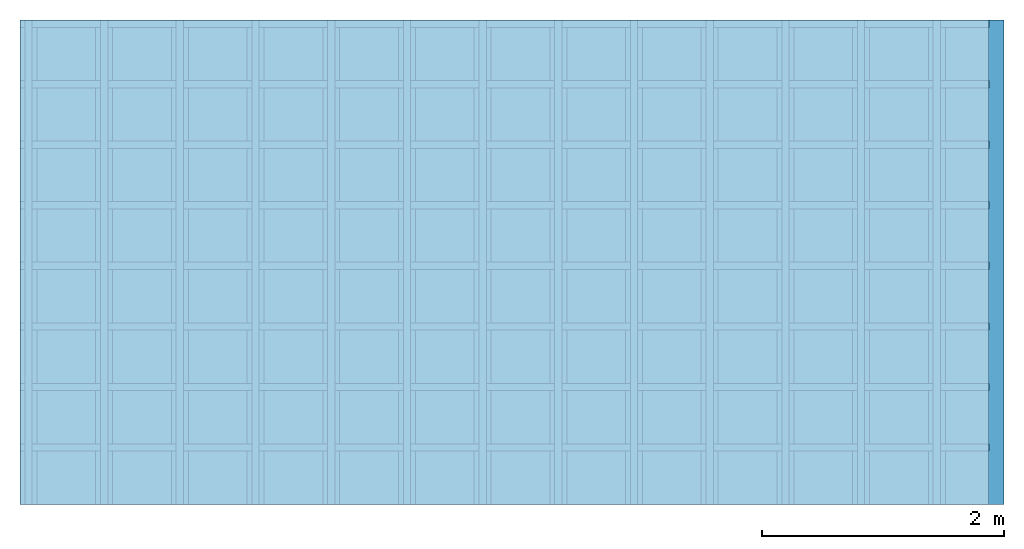
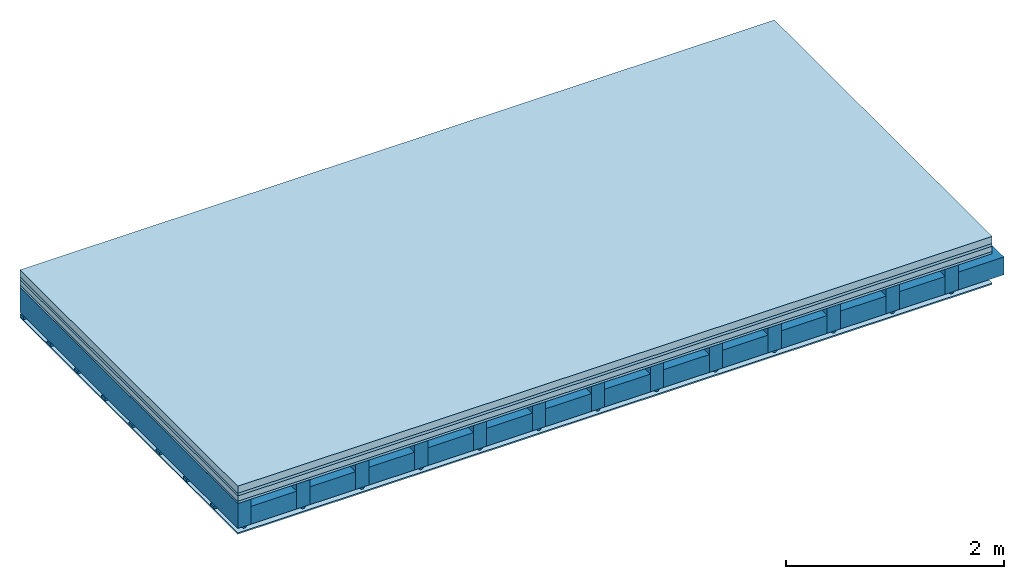
# One storey: 5 plates, 4 members, 1 element without a shape of its own.
"""IFC4 building model written with IfcOpenShell, lengths in metres."""

from ifc_helpers import new_model, si_unit, derived_unit, direction, frame, frame_2d, origin, origin_with_axes, place, context, project, spatial, polyline, rectangle, outline, extrude, material, layer, layer_set, type_object, element, aggregate, save


model = new_model("IFC4")

# Units and contexts
plan_context = context("Plan", 3, precision=1e-05, world=origin(), true_north=direction((0.0, 1.0)))
model_context = context("Model", 3, precision=1e-05, world=origin(), true_north=direction((0.0, 1.0)))
ifc_project = project(units=[si_unit("LENGTHUNIT", "METRE"), derived_unit("SOUNDPRESSUREUNIT", [(si_unit("PRESSUREUNIT", "PASCAL", prefix="MICRO"), 0)]), si_unit("ENERGYUNIT", "JOULE", prefix="MEGA"), si_unit("MASSUNIT", "GRAM", prefix="KILO"), derived_unit("THERMALTRANSMITTANCEUNIT", [(si_unit("POWERUNIT", "WATT"), 1), (si_unit("AREAUNIT", "SQUARE_METRE"), -1), (si_unit("THERMODYNAMICTEMPERATUREUNIT", "KELVIN"), -1)]), derived_unit("AREADENSITYUNIT", [(si_unit("MASSUNIT", "GRAM", prefix="KILO"), 1), (si_unit("AREAUNIT", "SQUARE_METRE"), -1)]), derived_unit("USERDEFINED", [(si_unit("ENERGYUNIT", "JOULE", prefix="MEGA"), 1), (si_unit("AREAUNIT", "SQUARE_METRE"), -1)])], contexts=[plan_context, model_context])

# Site, building, storey
site = spatial("IfcSite", under=ifc_project)
building_placement = place(None, origin())
building = spatial("IfcBuilding", under=site, at=building_placement)
storey_placement = place(building_placement, origin())
storey = spatial("IfcBuildingStorey", under=building, at=storey_placement)

# Slab, members, plates
ifc_material_1 = material(Name="Cement screed", Category="04.006")
ifc_layer_1 = layer(ifc_material_1, 0.08, Name="On-material")
ifc_material_2 = material()
ifc_layer_2 = layer(ifc_material_2, 0.03, Name="Impact sound insulation")
ifc_material_3 = material(Category="03.011")
ifc_layer_3 = layer(ifc_material_3, 0.06, Name="on Supporting structure")
ifc_material_4 = material(Category="07.001")
ifc_layer_4 = layer(ifc_material_4, 0.025, Name="Sub-floor")
ifc_material_5 = material(Name="of the art")
ifc_layer_5 = layer(ifc_material_5, 0.0, Name="Bond")
ifc_layer_6 = layer(None, 0.28, Name="Supporting structure")
ifc_material_6 = material(Name="no composite action")
ifc_layer_7 = layer(ifc_material_6, 0.0, Name="Bond")
ifc_layer_8 = layer(None, 0.02, Name="Coupling")
ifc_layer_9 = layer(None, 0.03, Name="Battens / profiles")
ifc_material_7 = material(Category="03.007")
ifc_layer_10 = layer(ifc_material_7, 0.015, Name="Ceiling covering 1st layer")
ifc_material_8 = material(Name="Glued joints")
ifc_layer_11 = layer(ifc_material_8, 0.0, Name="Surface / treatment")
ifc_layer_set = layer_set([ifc_layer_1, ifc_layer_2, ifc_layer_3, ifc_layer_4, ifc_layer_5, ifc_layer_6, ifc_layer_7, ifc_layer_8, ifc_layer_9, ifc_layer_10, ifc_layer_11])
slab_type = type_object("IfcSlabType", Name="A0266", PredefinedType="NOTDEFINED", material=ifc_layer_set)
slab_placement = place(None, frame((0.0, 0.0, 0.0), z_axis=(0.0, 0.0, -1.0), x_axis=(1.0, 0.0, 0.0)))
slab = element("IfcSlab", 1, at=slab_placement, inside=storey, type_object=slab_type, material=ifc_layer_set, Name="Slab #1")
ifc_material_9 = material()
member_1_placement = place(slab_placement, origin())
member_1 = element("IfcMember", 2, at=member_1_placement, material=ifc_material_9, Name="Supporting structure", context=plan_context, shape_type="SweptSolid", body=[
    extrude(rectangle(XDim=0.14, YDim=0.28, at=frame_2d((0.07, 0.14), x_axis=(1.0, 0.0))), frame((0.0, 4.0, 0.195), z_axis=(0.0, -1.0, 0.0), x_axis=(1.0, 0.0, 0.0)), (0.0, 0.0, 1.0), 4.0),
    extrude(rectangle(XDim=0.14, YDim=0.28, at=frame_2d((0.07, 0.14), x_axis=(1.0, 0.0))), frame((0.625, 4.0, 0.195), z_axis=(0.0, -1.0, 0.0), x_axis=(1.0, 0.0, 0.0)), (0.0, 0.0, 1.0), 4.0),
    extrude(rectangle(XDim=0.14, YDim=0.28, at=frame_2d((0.07, 0.14), x_axis=(1.0, 0.0))), frame((1.25, 4.0, 0.195), z_axis=(0.0, -1.0, 0.0), x_axis=(1.0, 0.0, 0.0)), (0.0, 0.0, 1.0), 4.0),
    extrude(rectangle(XDim=0.14, YDim=0.28, at=frame_2d((0.07, 0.14), x_axis=(1.0, 0.0))), frame((1.875, 4.0, 0.195), z_axis=(0.0, -1.0, 0.0), x_axis=(1.0, 0.0, 0.0)), (0.0, 0.0, 1.0), 4.0),
    extrude(rectangle(XDim=0.14, YDim=0.28, at=frame_2d((0.07, 0.14), x_axis=(1.0, 0.0))), frame((2.5, 4.0, 0.195), z_axis=(0.0, -1.0, 0.0), x_axis=(1.0, 0.0, 0.0)), (0.0, 0.0, 1.0), 4.0),
    extrude(rectangle(XDim=0.14, YDim=0.28, at=frame_2d((0.07, 0.14), x_axis=(1.0, 0.0))), frame((3.125, 4.0, 0.195), z_axis=(0.0, -1.0, 0.0), x_axis=(1.0, 0.0, 0.0)), (0.0, 0.0, 1.0), 4.0),
    extrude(rectangle(XDim=0.14, YDim=0.28, at=frame_2d((0.07, 0.14), x_axis=(1.0, 0.0))), frame((3.75, 4.0, 0.195), z_axis=(0.0, -1.0, 0.0), x_axis=(1.0, 0.0, 0.0)), (0.0, 0.0, 1.0), 4.0),
    extrude(rectangle(XDim=0.14, YDim=0.28, at=frame_2d((0.07, 0.14), x_axis=(1.0, 0.0))), frame((4.375, 4.0, 0.195), z_axis=(0.0, -1.0, 0.0), x_axis=(1.0, 0.0, 0.0)), (0.0, 0.0, 1.0), 4.0),
    extrude(rectangle(XDim=0.14, YDim=0.28, at=frame_2d((0.07, 0.14), x_axis=(1.0, 0.0))), frame((5.0, 4.0, 0.195), z_axis=(0.0, -1.0, 0.0), x_axis=(1.0, 0.0, 0.0)), (0.0, 0.0, 1.0), 4.0),
    extrude(rectangle(XDim=0.14, YDim=0.28, at=frame_2d((0.07, 0.14), x_axis=(1.0, 0.0))), frame((5.625, 4.0, 0.195), z_axis=(0.0, -1.0, 0.0), x_axis=(1.0, 0.0, 0.0)), (0.0, 0.0, 1.0), 4.0),
    extrude(rectangle(XDim=0.14, YDim=0.28, at=frame_2d((0.07, 0.14), x_axis=(1.0, 0.0))), frame((6.25, 4.0, 0.195), z_axis=(0.0, -1.0, 0.0), x_axis=(1.0, 0.0, 0.0)), (0.0, 0.0, 1.0), 4.0),
    extrude(rectangle(XDim=0.14, YDim=0.28, at=frame_2d((0.07, 0.14), x_axis=(1.0, 0.0))), frame((6.875, 4.0, 0.195), z_axis=(0.0, -1.0, 0.0), x_axis=(1.0, 0.0, 0.0)), (0.0, 0.0, 1.0), 4.0),
    extrude(rectangle(XDim=0.14, YDim=0.28, at=frame_2d((0.07, 0.14), x_axis=(1.0, 0.0))), frame((7.5, 4.0, 0.195), z_axis=(0.0, -1.0, 0.0), x_axis=(1.0, 0.0, 0.0)), (0.0, 0.0, 1.0), 4.0),
])
ifc_material_10 = material()
member_2_placement = place(slab_placement, origin())
member_2 = element("IfcMember", 3, at=member_2_placement, material=ifc_material_10, Name="Cavity", context=plan_context, shape_type="SweptSolid", body=[
    extrude(rectangle(XDim=0.485, YDim=0.2, at=frame_2d((0.2425, 0.1), x_axis=(1.0, 0.0))), frame((0.14, 4.0, 0.275), z_axis=(0.0, -1.0, 0.0), x_axis=(1.0, 0.0, 0.0)), (0.0, 0.0, 1.0), 4.0),
    extrude(rectangle(XDim=0.485, YDim=0.2, at=frame_2d((0.2425, 0.1), x_axis=(1.0, 0.0))), frame((0.765, 4.0, 0.275), z_axis=(0.0, -1.0, 0.0), x_axis=(1.0, 0.0, 0.0)), (0.0, 0.0, 1.0), 4.0),
    extrude(rectangle(XDim=0.485, YDim=0.2, at=frame_2d((0.2425, 0.1), x_axis=(1.0, 0.0))), frame((1.39, 4.0, 0.275), z_axis=(0.0, -1.0, 0.0), x_axis=(1.0, 0.0, 0.0)), (0.0, 0.0, 1.0), 4.0),
    extrude(rectangle(XDim=0.485, YDim=0.2, at=frame_2d((0.2425, 0.1), x_axis=(1.0, 0.0))), frame((2.015, 4.0, 0.275), z_axis=(0.0, -1.0, 0.0), x_axis=(1.0, 0.0, 0.0)), (0.0, 0.0, 1.0), 4.0),
    extrude(rectangle(XDim=0.485, YDim=0.2, at=frame_2d((0.2425, 0.1), x_axis=(1.0, 0.0))), frame((2.64, 4.0, 0.275), z_axis=(0.0, -1.0, 0.0), x_axis=(1.0, 0.0, 0.0)), (0.0, 0.0, 1.0), 4.0),
    extrude(rectangle(XDim=0.485, YDim=0.2, at=frame_2d((0.2425, 0.1), x_axis=(1.0, 0.0))), frame((3.265, 4.0, 0.275), z_axis=(0.0, -1.0, 0.0), x_axis=(1.0, 0.0, 0.0)), (0.0, 0.0, 1.0), 4.0),
    extrude(rectangle(XDim=0.485, YDim=0.2, at=frame_2d((0.2425, 0.1), x_axis=(1.0, 0.0))), frame((3.89, 4.0, 0.275), z_axis=(0.0, -1.0, 0.0), x_axis=(1.0, 0.0, 0.0)), (0.0, 0.0, 1.0), 4.0),
    extrude(rectangle(XDim=0.485, YDim=0.2, at=frame_2d((0.2425, 0.1), x_axis=(1.0, 0.0))), frame((4.515, 4.0, 0.275), z_axis=(0.0, -1.0, 0.0), x_axis=(1.0, 0.0, 0.0)), (0.0, 0.0, 1.0), 4.0),
    extrude(rectangle(XDim=0.485, YDim=0.2, at=frame_2d((0.2425, 0.1), x_axis=(1.0, 0.0))), frame((5.14, 4.0, 0.275), z_axis=(0.0, -1.0, 0.0), x_axis=(1.0, 0.0, 0.0)), (0.0, 0.0, 1.0), 4.0),
    extrude(rectangle(XDim=0.485, YDim=0.2, at=frame_2d((0.2425, 0.1), x_axis=(1.0, 0.0))), frame((5.765, 4.0, 0.275), z_axis=(0.0, -1.0, 0.0), x_axis=(1.0, 0.0, 0.0)), (0.0, 0.0, 1.0), 4.0),
    extrude(rectangle(XDim=0.485, YDim=0.2, at=frame_2d((0.2425, 0.1), x_axis=(1.0, 0.0))), frame((6.39, 4.0, 0.275), z_axis=(0.0, -1.0, 0.0), x_axis=(1.0, 0.0, 0.0)), (0.0, 0.0, 1.0), 4.0),
    extrude(rectangle(XDim=0.485, YDim=0.2, at=frame_2d((0.2425, 0.1), x_axis=(1.0, 0.0))), frame((7.015, 4.0, 0.275), z_axis=(0.0, -1.0, 0.0), x_axis=(1.0, 0.0, 0.0)), (0.0, 0.0, 1.0), 4.0),
    extrude(rectangle(XDim=0.485, YDim=0.2, at=frame_2d((0.2425, 0.1), x_axis=(1.0, 0.0))), frame((7.64, 4.0, 0.275), z_axis=(0.0, -1.0, 0.0), x_axis=(1.0, 0.0, 0.0)), (0.0, 0.0, 1.0), 4.0),
])
ifc_material_11 = material()
member_3_placement = place(slab_placement, origin())
member_3 = element("IfcMember", 4, at=member_3_placement, material=ifc_material_11, Name="Coupling", context=plan_context, shape_type="SweptSolid", body=[
    extrude(outline(polyline([(0.0, 0.0), (0.06, 0.0), (0.04, 0.02), (0.02, 0.02), (0.0, 0.0)])), frame((0.04, 4.0, 0.475), z_axis=(0.0, -1.0, 0.0), x_axis=(1.0, 0.0, 0.0)), (0.0, 0.0, 1.0), 4.0),
    extrude(outline(polyline([(0.0, 0.0), (0.06, 0.0), (0.04, 0.02), (0.02, 0.02), (0.0, 0.0)])), frame((0.665, 4.0, 0.475), z_axis=(0.0, -1.0, 0.0), x_axis=(1.0, 0.0, 0.0)), (0.0, 0.0, 1.0), 4.0),
    extrude(outline(polyline([(0.0, 0.0), (0.06, 0.0), (0.04, 0.02), (0.02, 0.02), (0.0, 0.0)])), frame((1.29, 4.0, 0.475), z_axis=(0.0, -1.0, 0.0), x_axis=(1.0, 0.0, 0.0)), (0.0, 0.0, 1.0), 4.0),
    extrude(outline(polyline([(0.0, 0.0), (0.06, 0.0), (0.04, 0.02), (0.02, 0.02), (0.0, 0.0)])), frame((1.915, 4.0, 0.475), z_axis=(0.0, -1.0, 0.0), x_axis=(1.0, 0.0, 0.0)), (0.0, 0.0, 1.0), 4.0),
    extrude(outline(polyline([(0.0, 0.0), (0.06, 0.0), (0.04, 0.02), (0.02, 0.02), (0.0, 0.0)])), frame((2.54, 4.0, 0.475), z_axis=(0.0, -1.0, 0.0), x_axis=(1.0, 0.0, 0.0)), (0.0, 0.0, 1.0), 4.0),
    extrude(outline(polyline([(0.0, 0.0), (0.06, 0.0), (0.04, 0.02), (0.02, 0.02), (0.0, 0.0)])), frame((3.165, 4.0, 0.475), z_axis=(0.0, -1.0, 0.0), x_axis=(1.0, 0.0, 0.0)), (0.0, 0.0, 1.0), 4.0),
    extrude(outline(polyline([(0.0, 0.0), (0.06, 0.0), (0.04, 0.02), (0.02, 0.02), (0.0, 0.0)])), frame((3.79, 4.0, 0.475), z_axis=(0.0, -1.0, 0.0), x_axis=(1.0, 0.0, 0.0)), (0.0, 0.0, 1.0), 4.0),
    extrude(outline(polyline([(0.0, 0.0), (0.06, 0.0), (0.04, 0.02), (0.02, 0.02), (0.0, 0.0)])), frame((4.415, 4.0, 0.475), z_axis=(0.0, -1.0, 0.0), x_axis=(1.0, 0.0, 0.0)), (0.0, 0.0, 1.0), 4.0),
    extrude(outline(polyline([(0.0, 0.0), (0.06, 0.0), (0.04, 0.02), (0.02, 0.02), (0.0, 0.0)])), frame((5.04, 4.0, 0.475), z_axis=(0.0, -1.0, 0.0), x_axis=(1.0, 0.0, 0.0)), (0.0, 0.0, 1.0), 4.0),
    extrude(outline(polyline([(0.0, 0.0), (0.06, 0.0), (0.04, 0.02), (0.02, 0.02), (0.0, 0.0)])), frame((5.665, 4.0, 0.475), z_axis=(0.0, -1.0, 0.0), x_axis=(1.0, 0.0, 0.0)), (0.0, 0.0, 1.0), 4.0),
    extrude(outline(polyline([(0.0, 0.0), (0.06, 0.0), (0.04, 0.02), (0.02, 0.02), (0.0, 0.0)])), frame((6.29, 4.0, 0.475), z_axis=(0.0, -1.0, 0.0), x_axis=(1.0, 0.0, 0.0)), (0.0, 0.0, 1.0), 4.0),
    extrude(outline(polyline([(0.0, 0.0), (0.06, 0.0), (0.04, 0.02), (0.02, 0.02), (0.0, 0.0)])), frame((6.915, 4.0, 0.475), z_axis=(0.0, -1.0, 0.0), x_axis=(1.0, 0.0, 0.0)), (0.0, 0.0, 1.0), 4.0),
    extrude(outline(polyline([(0.0, 0.0), (0.06, 0.0), (0.04, 0.02), (0.02, 0.02), (0.0, 0.0)])), frame((7.54, 4.0, 0.475), z_axis=(0.0, -1.0, 0.0), x_axis=(1.0, 0.0, 0.0)), (0.0, 0.0, 1.0), 4.0),
])
ifc_material_12 = material()
member_4_placement = place(slab_placement, origin())
member_4 = element("IfcMember", 5, at=member_4_placement, material=ifc_material_12, Name="Battens / profiles", context=plan_context, shape_type="SweptSolid", body=[
    extrude(rectangle(XDim=0.06, YDim=0.03, at=frame_2d((0.03, 0.015), x_axis=(1.0, 0.0))), frame((0.0, 0.0, 0.495), z_axis=(1.0, 0.0, 0.0), x_axis=(0.0, 1.0, 0.0)), (0.0, 0.0, 1.0), 8.0),
    extrude(rectangle(XDim=0.06, YDim=0.03, at=frame_2d((0.03, 0.015), x_axis=(1.0, 0.0))), frame((0.0, 0.5, 0.495), z_axis=(1.0, 0.0, 0.0), x_axis=(0.0, 1.0, 0.0)), (0.0, 0.0, 1.0), 8.0),
    extrude(rectangle(XDim=0.06, YDim=0.03, at=frame_2d((0.03, 0.015), x_axis=(1.0, 0.0))), frame((0.0, 1.0, 0.495), z_axis=(1.0, 0.0, 0.0), x_axis=(0.0, 1.0, 0.0)), (0.0, 0.0, 1.0), 8.0),
    extrude(rectangle(XDim=0.06, YDim=0.03, at=frame_2d((0.03, 0.015), x_axis=(1.0, 0.0))), frame((0.0, 1.5, 0.495), z_axis=(1.0, 0.0, 0.0), x_axis=(0.0, 1.0, 0.0)), (0.0, 0.0, 1.0), 8.0),
    extrude(rectangle(XDim=0.06, YDim=0.03, at=frame_2d((0.03, 0.015), x_axis=(1.0, 0.0))), frame((0.0, 2.0, 0.495), z_axis=(1.0, 0.0, 0.0), x_axis=(0.0, 1.0, 0.0)), (0.0, 0.0, 1.0), 8.0),
    extrude(rectangle(XDim=0.06, YDim=0.03, at=frame_2d((0.03, 0.015), x_axis=(1.0, 0.0))), frame((0.0, 2.5, 0.495), z_axis=(1.0, 0.0, 0.0), x_axis=(0.0, 1.0, 0.0)), (0.0, 0.0, 1.0), 8.0),
    extrude(rectangle(XDim=0.06, YDim=0.03, at=frame_2d((0.03, 0.015), x_axis=(1.0, 0.0))), frame((0.0, 3.0, 0.495), z_axis=(1.0, 0.0, 0.0), x_axis=(0.0, 1.0, 0.0)), (0.0, 0.0, 1.0), 8.0),
    extrude(rectangle(XDim=0.06, YDim=0.03, at=frame_2d((0.03, 0.015), x_axis=(1.0, 0.0))), frame((0.0, 3.5, 0.495), z_axis=(1.0, 0.0, 0.0), x_axis=(0.0, 1.0, 0.0)), (0.0, 0.0, 1.0), 8.0),
])
plate_1_placement = place(slab_placement, origin())
plate_1 = element("IfcPlate", 6, at=plate_1_placement, material=ifc_material_1, Name="On-material", context=plan_context, shape_type="SweptSolid", body=[
    extrude(rectangle(XDim=8.0, YDim=4.0, at=frame_2d((4.0, 2.0), x_axis=(1.0, 0.0))), origin_with_axes(), (0.0, 0.0, 1.0), 0.08),
])
plate_2_placement = place(slab_placement, origin())
plate_2 = element("IfcPlate", 7, at=plate_2_placement, material=ifc_material_2, Name="Impact sound insulation", context=plan_context, shape_type="SweptSolid", body=[
    extrude(rectangle(XDim=8.0, YDim=4.0, at=frame_2d((4.0, 2.0), x_axis=(1.0, 0.0))), frame((0.0, 0.0, 0.08), z_axis=(0.0, 0.0, 1.0), x_axis=(1.0, 0.0, 0.0)), (0.0, 0.0, 1.0), 0.03),
])
plate_3_placement = place(slab_placement, origin())
plate_3 = element("IfcPlate", 8, at=plate_3_placement, material=ifc_material_3, Name="on Supporting structure", context=plan_context, shape_type="SweptSolid", body=[
    extrude(rectangle(XDim=8.0, YDim=4.0, at=frame_2d((4.0, 2.0), x_axis=(1.0, 0.0))), frame((0.0, 0.0, 0.11), z_axis=(0.0, 0.0, 1.0), x_axis=(1.0, 0.0, 0.0)), (0.0, 0.0, 1.0), 0.06),
])
plate_4_placement = place(slab_placement, origin())
plate_4 = element("IfcPlate", 9, at=plate_4_placement, material=ifc_material_4, Name="Sub-floor", context=plan_context, shape_type="SweptSolid", body=[
    extrude(rectangle(XDim=8.0, YDim=4.0, at=frame_2d((4.0, 2.0), x_axis=(1.0, 0.0))), frame((0.0, 0.0, 0.17), z_axis=(0.0, 0.0, 1.0), x_axis=(1.0, 0.0, 0.0)), (0.0, 0.0, 1.0), 0.025),
])
plate_5_placement = place(slab_placement, origin())
plate_5 = element("IfcPlate", 10, at=plate_5_placement, material=ifc_material_7, Name="Ceiling covering 1st layer", context=plan_context, shape_type="SweptSolid", body=[
    extrude(rectangle(XDim=8.0, YDim=4.0, at=frame_2d((4.0, 2.0), x_axis=(1.0, 0.0))), frame((0.0, 0.0, 0.525), z_axis=(0.0, 0.0, 1.0), x_axis=(1.0, 0.0, 0.0)), (0.0, 0.0, 1.0), 0.015),
])
aggregate(slab, [plate_1, plate_2, plate_3, plate_4, member_1, member_2, member_3, member_4, plate_5])

save(model, "model.ifc")
